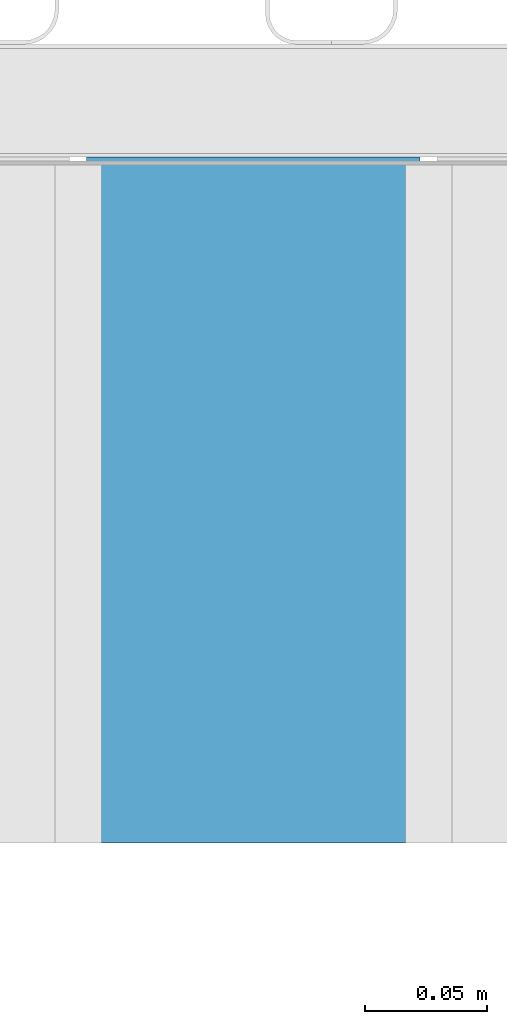
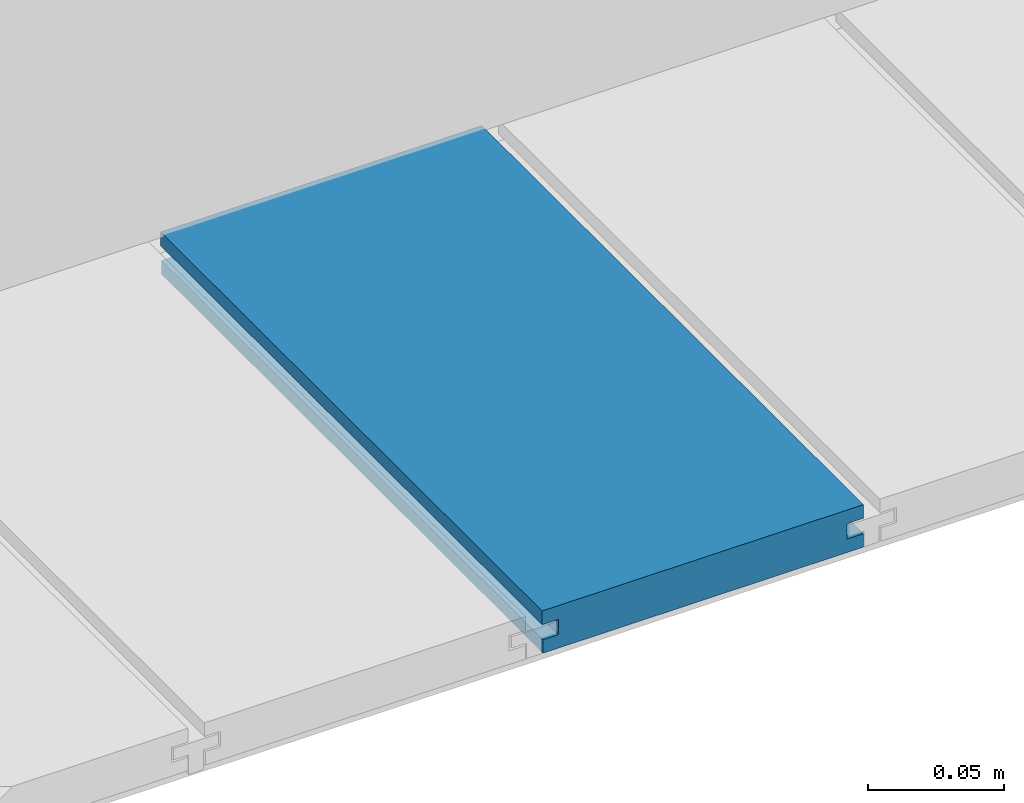
# One storey, part 14 of 33: 1 wall.
"""IFC4 building model written with IfcOpenShell, lengths in feet."""

from ifc_helpers import new_model, entity, si_unit, converted_unit, derived_unit, direction, frame, origin, place, context, subcontext, project, spatial, material, type_object, element, save


model = new_model("IFC4")

# Units and contexts
model_context = context("Model", 3, precision=0.0001, world=origin(), true_north=direction((6.12303176911189e-17, 1.0)))
body_context = subcontext(model_context, "Body", "Model", "MODEL_VIEW")
ifc_project = project(units=[converted_unit("LENGTHUNIT", "FOOT", entity("IfcRatioMeasure", 0.3048), si_unit("LENGTHUNIT", "METRE"), dimensions=[1, 0, 0, 0, 0, 0, 0]), converted_unit("AREAUNIT", "SQUARE FOOT", entity("IfcRatioMeasure", 0.09290304), si_unit("AREAUNIT", "SQUARE_METRE"), dimensions=[2, 0, 0, 0, 0, 0, 0]), converted_unit("VOLUMEUNIT", "CUBIC FOOT", entity("IfcRatioMeasure", 0.028316846592), si_unit("VOLUMEUNIT", "CUBIC_METRE"), dimensions=[3, 0, 0, 0, 0, 0, 0]), converted_unit("PLANEANGLEUNIT", "DEGREE", entity("IfcRatioMeasure", 0.0174532925199433), si_unit("PLANEANGLEUNIT", "RADIAN"), dimensions=[0, 0, 0, 0, 0, 0, 0]), si_unit("MASSUNIT", "GRAM", prefix="KILO"), derived_unit("MASSDENSITYUNIT", [(si_unit("MASSUNIT", "GRAM", prefix="KILO"), 1), (si_unit("LENGTHUNIT", "METRE"), -3)]), derived_unit("MOMENTOFINERTIAUNIT", [(si_unit("LENGTHUNIT", "METRE"), 4)]), si_unit("TIMEUNIT", "SECOND"), si_unit("FREQUENCYUNIT", "HERTZ"), si_unit("THERMODYNAMICTEMPERATUREUNIT", "DEGREE_CELSIUS"), derived_unit("THERMALTRANSMITTANCEUNIT", [(si_unit("MASSUNIT", "GRAM", prefix="KILO"), 1), (si_unit("THERMODYNAMICTEMPERATUREUNIT", "KELVIN"), -1), (si_unit("TIMEUNIT", "SECOND"), -3)]), derived_unit("VOLUMETRICFLOWRATEUNIT", [(si_unit("LENGTHUNIT", "METRE"), 3), (si_unit("TIMEUNIT", "SECOND"), -1)]), si_unit("ELECTRICCURRENTUNIT", "AMPERE"), si_unit("ELECTRICVOLTAGEUNIT", "VOLT"), si_unit("POWERUNIT", "WATT"), si_unit("FORCEUNIT", "NEWTON"), si_unit("ILLUMINANCEUNIT", "LUX"), si_unit("LUMINOUSFLUXUNIT", "LUMEN"), si_unit("LUMINOUSINTENSITYUNIT", "CANDELA"), derived_unit("USERDEFINED", [(si_unit("MASSUNIT", "GRAM", prefix="KILO"), -1), (si_unit("LENGTHUNIT", "METRE"), -2), (si_unit("TIMEUNIT", "SECOND"), 3), (si_unit("LUMINOUSFLUXUNIT", "LUMEN"), 1)]), derived_unit("LINEARVELOCITYUNIT", [(si_unit("LENGTHUNIT", "METRE"), 1), (si_unit("TIMEUNIT", "SECOND"), -1)]), si_unit("PRESSUREUNIT", "PASCAL"), derived_unit("USERDEFINED", [(si_unit("LENGTHUNIT", "METRE"), -2), (si_unit("MASSUNIT", "GRAM", prefix="KILO"), 1), (si_unit("TIMEUNIT", "SECOND"), -2)]), derived_unit("LINEARFORCEUNIT", [(si_unit("MASSUNIT", "GRAM", prefix="KILO"), 1), (si_unit("LENGTHUNIT", "METRE"), 1), (si_unit("TIMEUNIT", "SECOND"), -2), (si_unit("LENGTHUNIT", "METRE"), -1)]), derived_unit("PLANARFORCEUNIT", [(si_unit("MASSUNIT", "GRAM", prefix="KILO"), 1), (si_unit("LENGTHUNIT", "METRE"), 1), (si_unit("TIMEUNIT", "SECOND"), -2), (si_unit("LENGTHUNIT", "METRE"), -2)])], contexts=[model_context])

# Site, building, storey
site_placement = place(None, origin())
site = spatial("IfcSite", under=ifc_project, at=site_placement, CompositionType="ELEMENT")
building_placement = place(site_placement, origin())
building = spatial("IfcBuilding", under=site, at=building_placement, CompositionType="ELEMENT")
storey_placement = place(building_placement, frame((0.0, 0.0, 10.0)))
storey = spatial("IfcBuildingStorey", under=building, at=storey_placement, Name="2ND FLOOR", CompositionType="ELEMENT", Elevation=10.0000000000002)

# Wall
ifc_material = material(Name="COMPOSITE DECKING W/ HIDDEN FASTENERS", Category="Materials")
wall_type = type_object("IfcWallType", Name="Generic Models 728:Generic Models 1", PredefinedType="NOTDEFINED", material=ifc_material)
wall_placement = place(storey_placement, frame((1488.7128250319, 3.04611392999271, 0.682902157150146), z_axis=(0.0, 0.0, 1.0), x_axis=(0.0, 1.0, 0.0)))
cartesian_point_1 = entity("IfcCartesianPoint", [0.919003339851618, -0.446740923891412, 0.0])
vertex_point_1 = entity("IfcVertexPoint", cartesian_point_1)
cartesian_point_2 = entity("IfcCartesianPoint", [0.91900333985162, -0.00132475379450625, 0.0])
vertex_point_2 = entity("IfcVertexPoint", cartesian_point_2)
ifc_direction_1 = entity("IfcDirection", [0.0, 1.0, 0.0])
edge_curve_1 = entity("IfcEdgeCurve", vertex_point_1, vertex_point_2, entity("IfcTrimmedCurve", entity("IfcLine", cartesian_point_1, entity("IfcVector", ifc_direction_1, 1.0)), [cartesian_point_1], [cartesian_point_2], True, "CARTESIAN"), True)
cartesian_point_3 = entity("IfcCartesianPoint", [0.91900333985162, -0.00132475379450625, 0.0198779960861462])
vertex_point_3 = entity("IfcVertexPoint", cartesian_point_3)
ifc_direction_2 = entity("IfcDirection", [0.0, 0.0, 1.0])
edge_curve_2 = entity("IfcEdgeCurve", vertex_point_2, vertex_point_3, entity("IfcTrimmedCurve", entity("IfcLine", cartesian_point_2, entity("IfcVector", ifc_direction_2, 1.0)), [cartesian_point_2], [cartesian_point_3], True, "CARTESIAN"), True)
cartesian_point_4 = entity("IfcCartesianPoint", [0.91900333985162, -0.0228400010807945, 0.0198779960861462])
vertex_point_4 = entity("IfcVertexPoint", cartesian_point_4)
ifc_direction_3 = entity("IfcDirection", [0.0, -1.0, 0.0])
edge_curve_3 = entity("IfcEdgeCurve", vertex_point_3, vertex_point_4, entity("IfcTrimmedCurve", entity("IfcLine", cartesian_point_3, entity("IfcVector", ifc_direction_3, 1.0)), [cartesian_point_3], [cartesian_point_4], True, "CARTESIAN"), True)
cartesian_point_5 = entity("IfcCartesianPoint", [0.91900333985162, -0.0228400010807945, 0.0422987663426522])
vertex_point_5 = entity("IfcVertexPoint", cartesian_point_5)
edge_curve_4 = entity("IfcEdgeCurve", vertex_point_4, vertex_point_5, entity("IfcTrimmedCurve", entity("IfcLine", cartesian_point_4, entity("IfcVector", ifc_direction_2, 1.0)), [cartesian_point_4], [cartesian_point_5], True, "CARTESIAN"), True)
cartesian_point_6 = entity("IfcCartesianPoint", [0.91900333985162, 0.0, 0.0422987663426522])
vertex_point_6 = entity("IfcVertexPoint", cartesian_point_6)
edge_curve_5 = entity("IfcEdgeCurve", vertex_point_5, vertex_point_6, entity("IfcTrimmedCurve", entity("IfcLine", cartesian_point_5, entity("IfcVector", ifc_direction_1, 1.0)), [cartesian_point_5], [cartesian_point_6], True, "CARTESIAN"), True)
cartesian_point_7 = entity("IfcCartesianPoint", [0.91900333985162, 0.0, 0.0625000000000551])
vertex_point_7 = entity("IfcVertexPoint", cartesian_point_7)
edge_curve_6 = entity("IfcEdgeCurve", vertex_point_6, vertex_point_7, entity("IfcTrimmedCurve", entity("IfcLine", cartesian_point_6, entity("IfcVector", ifc_direction_2, 1.0)), [cartesian_point_6], [cartesian_point_7], True, "CARTESIAN"), True)
cartesian_point_8 = entity("IfcCartesianPoint", [0.919003339851618, -0.446740923891639, 0.0624999999999982])
vertex_point_8 = entity("IfcVertexPoint", cartesian_point_8)
edge_curve_7 = entity("IfcEdgeCurve", vertex_point_7, vertex_point_8, entity("IfcTrimmedCurve", entity("IfcLine", cartesian_point_7, entity("IfcVector", ifc_direction_3, 1.0)), [cartesian_point_7], [cartesian_point_8], True, "CARTESIAN"), True)
cartesian_point_9 = entity("IfcCartesianPoint", [0.919003339851618, -0.446740923891639, 0.0422987663426522])
vertex_point_9 = entity("IfcVertexPoint", cartesian_point_9)
ifc_direction_4 = entity("IfcDirection", [0.0, 0.0, -1.0])
edge_curve_8 = entity("IfcEdgeCurve", vertex_point_8, vertex_point_9, entity("IfcTrimmedCurve", entity("IfcLine", cartesian_point_8, entity("IfcVector", ifc_direction_4, 1.0)), [cartesian_point_8], [cartesian_point_9], True, "CARTESIAN"), True)
cartesian_point_10 = entity("IfcCartesianPoint", [0.919003339851618, -0.423900922810617, 0.0422987663426522])
vertex_point_10 = entity("IfcVertexPoint", cartesian_point_10)
edge_curve_9 = entity("IfcEdgeCurve", vertex_point_9, vertex_point_10, entity("IfcTrimmedCurve", entity("IfcLine", cartesian_point_9, entity("IfcVector", ifc_direction_1, 1.0)), [cartesian_point_9], [cartesian_point_10], True, "CARTESIAN"), True)
cartesian_point_11 = entity("IfcCartesianPoint", [0.919003339851618, -0.423900922810617, 0.0198779960861462])
vertex_point_11 = entity("IfcVertexPoint", cartesian_point_11)
edge_curve_10 = entity("IfcEdgeCurve", vertex_point_10, vertex_point_11, entity("IfcTrimmedCurve", entity("IfcLine", cartesian_point_10, entity("IfcVector", ifc_direction_4, 1.0)), [cartesian_point_10], [cartesian_point_11], True, "CARTESIAN"), True)
cartesian_point_12 = entity("IfcCartesianPoint", [0.919003339851618, -0.446740923891412, 0.0198779960861462])
vertex_point_12 = entity("IfcVertexPoint", cartesian_point_12)
edge_curve_11 = entity("IfcEdgeCurve", vertex_point_11, vertex_point_12, entity("IfcTrimmedCurve", entity("IfcLine", cartesian_point_11, entity("IfcVector", ifc_direction_3, 1.0)), [cartesian_point_11], [cartesian_point_12], True, "CARTESIAN"), True)
edge_curve_12 = entity("IfcEdgeCurve", vertex_point_12, vertex_point_1, entity("IfcTrimmedCurve", entity("IfcLine", cartesian_point_12, entity("IfcVector", ifc_direction_4, 1.0)), [cartesian_point_12], [cartesian_point_1], True, "CARTESIAN"), True)
ifc_direction_5 = entity("IfcDirection", [1.0, 0.0, 0.0])
cartesian_point_13 = entity("IfcCartesianPoint", [0.0, -0.446740923891412, 0.0])
vertex_point_13 = entity("IfcVertexPoint", cartesian_point_13)
cartesian_point_14 = entity("IfcCartesianPoint", [0.0, -0.446740923891412, 0.0198779960861462])
vertex_point_14 = entity("IfcVertexPoint", cartesian_point_14)
edge_curve_13 = entity("IfcEdgeCurve", vertex_point_13, vertex_point_14, entity("IfcTrimmedCurve", entity("IfcLine", cartesian_point_13, entity("IfcVector", ifc_direction_2, 1.0)), [cartesian_point_13], [cartesian_point_14], True, "CARTESIAN"), True)
cartesian_point_15 = entity("IfcCartesianPoint", [0.0, -0.423900922810617, 0.0198779960861462])
vertex_point_15 = entity("IfcVertexPoint", cartesian_point_15)
edge_curve_14 = entity("IfcEdgeCurve", vertex_point_14, vertex_point_15, entity("IfcTrimmedCurve", entity("IfcLine", cartesian_point_14, entity("IfcVector", ifc_direction_1, 1.0)), [cartesian_point_14], [cartesian_point_15], True, "CARTESIAN"), True)
cartesian_point_16 = entity("IfcCartesianPoint", [0.0, -0.423900922810617, 0.0422987663426522])
vertex_point_16 = entity("IfcVertexPoint", cartesian_point_16)
edge_curve_15 = entity("IfcEdgeCurve", vertex_point_15, vertex_point_16, entity("IfcTrimmedCurve", entity("IfcLine", cartesian_point_15, entity("IfcVector", ifc_direction_2, 1.0)), [cartesian_point_15], [cartesian_point_16], True, "CARTESIAN"), True)
cartesian_point_17 = entity("IfcCartesianPoint", [0.0, -0.446740923891639, 0.0422987663426522])
vertex_point_17 = entity("IfcVertexPoint", cartesian_point_17)
edge_curve_16 = entity("IfcEdgeCurve", vertex_point_16, vertex_point_17, entity("IfcTrimmedCurve", entity("IfcLine", cartesian_point_16, entity("IfcVector", ifc_direction_3, 1.0)), [cartesian_point_16], [cartesian_point_17], True, "CARTESIAN"), True)
cartesian_point_18 = entity("IfcCartesianPoint", [0.0, -0.446740923891639, 0.0624999999999982])
vertex_point_18 = entity("IfcVertexPoint", cartesian_point_18)
edge_curve_17 = entity("IfcEdgeCurve", vertex_point_17, vertex_point_18, entity("IfcTrimmedCurve", entity("IfcLine", cartesian_point_17, entity("IfcVector", ifc_direction_2, 1.0)), [cartesian_point_17], [cartesian_point_18], True, "CARTESIAN"), True)
cartesian_point_19 = entity("IfcCartesianPoint", [0.0, 0.0, 0.0625000000000551])
vertex_point_19 = entity("IfcVertexPoint", cartesian_point_19)
edge_curve_18 = entity("IfcEdgeCurve", vertex_point_18, vertex_point_19, entity("IfcTrimmedCurve", entity("IfcLine", cartesian_point_18, entity("IfcVector", ifc_direction_1, 1.0)), [cartesian_point_18], [cartesian_point_19], True, "CARTESIAN"), True)
cartesian_point_20 = entity("IfcCartesianPoint", [0.0, 0.0, 0.0422987663426522])
vertex_point_20 = entity("IfcVertexPoint", cartesian_point_20)
edge_curve_19 = entity("IfcEdgeCurve", vertex_point_19, vertex_point_20, entity("IfcTrimmedCurve", entity("IfcLine", cartesian_point_19, entity("IfcVector", ifc_direction_4, 1.0)), [cartesian_point_19], [cartesian_point_20], True, "CARTESIAN"), True)
cartesian_point_21 = entity("IfcCartesianPoint", [0.0, -0.0228400010807945, 0.0422987663426522])
vertex_point_21 = entity("IfcVertexPoint", cartesian_point_21)
edge_curve_20 = entity("IfcEdgeCurve", vertex_point_20, vertex_point_21, entity("IfcTrimmedCurve", entity("IfcLine", cartesian_point_20, entity("IfcVector", ifc_direction_3, 1.0)), [cartesian_point_20], [cartesian_point_21], True, "CARTESIAN"), True)
cartesian_point_22 = entity("IfcCartesianPoint", [0.0, -0.0228400010807945, 0.0198779960861462])
vertex_point_22 = entity("IfcVertexPoint", cartesian_point_22)
edge_curve_21 = entity("IfcEdgeCurve", vertex_point_21, vertex_point_22, entity("IfcTrimmedCurve", entity("IfcLine", cartesian_point_21, entity("IfcVector", ifc_direction_4, 1.0)), [cartesian_point_21], [cartesian_point_22], True, "CARTESIAN"), True)
cartesian_point_23 = entity("IfcCartesianPoint", [0.0, -0.00132475379450625, 0.0198779960861462])
vertex_point_23 = entity("IfcVertexPoint", cartesian_point_23)
edge_curve_22 = entity("IfcEdgeCurve", vertex_point_22, vertex_point_23, entity("IfcTrimmedCurve", entity("IfcLine", cartesian_point_22, entity("IfcVector", ifc_direction_1, 1.0)), [cartesian_point_22], [cartesian_point_23], True, "CARTESIAN"), True)
cartesian_point_24 = entity("IfcCartesianPoint", [0.0, -0.00132475379450625, 0.0])
vertex_point_24 = entity("IfcVertexPoint", cartesian_point_24)
edge_curve_23 = entity("IfcEdgeCurve", vertex_point_23, vertex_point_24, entity("IfcTrimmedCurve", entity("IfcLine", cartesian_point_23, entity("IfcVector", ifc_direction_4, 1.0)), [cartesian_point_23], [cartesian_point_24], True, "CARTESIAN"), True)
edge_curve_24 = entity("IfcEdgeCurve", vertex_point_24, vertex_point_13, entity("IfcTrimmedCurve", entity("IfcLine", cartesian_point_24, entity("IfcVector", ifc_direction_3, 1.0)), [cartesian_point_24], [cartesian_point_13], True, "CARTESIAN"), True)
ifc_direction_6 = entity("IfcDirection", [-1.0, 0.0, 0.0])
edge_curve_25 = entity("IfcEdgeCurve", vertex_point_13, vertex_point_1, entity("IfcTrimmedCurve", entity("IfcLine", cartesian_point_13, entity("IfcVector", ifc_direction_5, 1.0)), [cartesian_point_13], [cartesian_point_1], True, "CARTESIAN"), True)
edge_curve_26 = entity("IfcEdgeCurve", vertex_point_12, vertex_point_14, entity("IfcTrimmedCurve", entity("IfcLine", cartesian_point_14, entity("IfcVector", ifc_direction_6, 1.0)), [cartesian_point_12], [cartesian_point_14], True, "CARTESIAN"), True)
edge_curve_27 = entity("IfcEdgeCurve", vertex_point_18, vertex_point_8, entity("IfcTrimmedCurve", entity("IfcLine", cartesian_point_18, entity("IfcVector", ifc_direction_5, 1.0)), [cartesian_point_18], [cartesian_point_8], True, "CARTESIAN"), True)
edge_curve_28 = entity("IfcEdgeCurve", vertex_point_7, vertex_point_19, entity("IfcTrimmedCurve", entity("IfcLine", cartesian_point_19, entity("IfcVector", ifc_direction_6, 1.0)), [cartesian_point_7], [cartesian_point_19], True, "CARTESIAN"), True)
edge_curve_29 = entity("IfcEdgeCurve", vertex_point_6, vertex_point_20, entity("IfcTrimmedCurve", entity("IfcLine", cartesian_point_20, entity("IfcVector", ifc_direction_6, 1.0)), [cartesian_point_6], [cartesian_point_20], True, "CARTESIAN"), True)
edge_curve_30 = entity("IfcEdgeCurve", vertex_point_24, vertex_point_2, entity("IfcTrimmedCurve", entity("IfcLine", cartesian_point_24, entity("IfcVector", ifc_direction_5, 1.0)), [cartesian_point_24], [cartesian_point_2], True, "CARTESIAN"), True)
edge_curve_31 = entity("IfcEdgeCurve", vertex_point_17, vertex_point_9, entity("IfcTrimmedCurve", entity("IfcLine", cartesian_point_17, entity("IfcVector", ifc_direction_5, 1.0)), [cartesian_point_17], [cartesian_point_9], True, "CARTESIAN"), True)
edge_curve_32 = entity("IfcEdgeCurve", vertex_point_5, vertex_point_21, entity("IfcTrimmedCurve", entity("IfcLine", cartesian_point_21, entity("IfcVector", ifc_direction_6, 1.0)), [cartesian_point_5], [cartesian_point_21], True, "CARTESIAN"), True)
edge_curve_33 = entity("IfcEdgeCurve", vertex_point_4, vertex_point_22, entity("IfcTrimmedCurve", entity("IfcLine", cartesian_point_22, entity("IfcVector", ifc_direction_6, 1.0)), [cartesian_point_4], [cartesian_point_22], True, "CARTESIAN"), True)
edge_curve_34 = entity("IfcEdgeCurve", vertex_point_3, vertex_point_23, entity("IfcTrimmedCurve", entity("IfcLine", cartesian_point_23, entity("IfcVector", ifc_direction_6, 1.0)), [cartesian_point_3], [cartesian_point_23], True, "CARTESIAN"), True)
edge_curve_35 = entity("IfcEdgeCurve", vertex_point_11, vertex_point_15, entity("IfcTrimmedCurve", entity("IfcLine", cartesian_point_15, entity("IfcVector", ifc_direction_6, 1.0)), [cartesian_point_11], [cartesian_point_15], True, "CARTESIAN"), True)
edge_curve_36 = entity("IfcEdgeCurve", vertex_point_10, vertex_point_16, entity("IfcTrimmedCurve", entity("IfcLine", cartesian_point_16, entity("IfcVector", ifc_direction_6, 1.0)), [cartesian_point_10], [cartesian_point_16], True, "CARTESIAN"), True)
element("IfcWall", 1, at=wall_placement, inside=storey, type_object=wall_type, material=ifc_material, Name="Generic Models 728:Generic Models 1", ObjectType="Generic Models 728:Generic Models 1", PredefinedType="NOTDEFINED", context=body_context, shape_type="AdvancedBrep", body=[
    entity("IfcAdvancedBrep", entity("IfcClosedShell", [entity("IfcAdvancedFace", [entity("IfcFaceOuterBound", entity("IfcEdgeLoop", [entity("IfcOrientedEdge", None, None, edge_curve_1, True), entity("IfcOrientedEdge", None, None, edge_curve_2, True), entity("IfcOrientedEdge", None, None, edge_curve_3, True), entity("IfcOrientedEdge", None, None, edge_curve_4, True), entity("IfcOrientedEdge", None, None, edge_curve_5, True), entity("IfcOrientedEdge", None, None, edge_curve_6, True), entity("IfcOrientedEdge", None, None, edge_curve_7, True), entity("IfcOrientedEdge", None, None, edge_curve_8, True), entity("IfcOrientedEdge", None, None, edge_curve_9, True), entity("IfcOrientedEdge", None, None, edge_curve_10, True), entity("IfcOrientedEdge", None, None, edge_curve_11, True), entity("IfcOrientedEdge", None, None, edge_curve_12, True)]), True)], entity("IfcPlane", entity("IfcAxis2Placement3D", entity("IfcCartesianPoint", [0.919003339851618, -0.446740923891412, -0.0208333333328241]), ifc_direction_5, ifc_direction_4)), True), entity("IfcAdvancedFace", [entity("IfcFaceOuterBound", entity("IfcEdgeLoop", [entity("IfcOrientedEdge", None, None, edge_curve_13, True), entity("IfcOrientedEdge", None, None, edge_curve_14, True), entity("IfcOrientedEdge", None, None, edge_curve_15, True), entity("IfcOrientedEdge", None, None, edge_curve_16, True), entity("IfcOrientedEdge", None, None, edge_curve_17, True), entity("IfcOrientedEdge", None, None, edge_curve_18, True), entity("IfcOrientedEdge", None, None, edge_curve_19, True), entity("IfcOrientedEdge", None, None, edge_curve_20, True), entity("IfcOrientedEdge", None, None, edge_curve_21, True), entity("IfcOrientedEdge", None, None, edge_curve_22, True), entity("IfcOrientedEdge", None, None, edge_curve_23, True), entity("IfcOrientedEdge", None, None, edge_curve_24, True)]), True)], entity("IfcPlane", entity("IfcAxis2Placement3D", entity("IfcCartesianPoint", [0.0, -0.446740923891412, -0.0208333333328241]), ifc_direction_6, ifc_direction_2)), True), entity("IfcAdvancedFace", [entity("IfcFaceOuterBound", entity("IfcEdgeLoop", [entity("IfcOrientedEdge", None, None, edge_curve_13, False), entity("IfcOrientedEdge", None, None, edge_curve_25, True), entity("IfcOrientedEdge", None, None, edge_curve_12, False), entity("IfcOrientedEdge", None, None, edge_curve_26, True)]), True)], entity("IfcPlane", entity("IfcAxis2Placement3D", cartesian_point_13, ifc_direction_3, ifc_direction_5)), True), entity("IfcAdvancedFace", [entity("IfcFaceOuterBound", entity("IfcEdgeLoop", [entity("IfcOrientedEdge", None, None, edge_curve_18, False), entity("IfcOrientedEdge", None, None, edge_curve_27, True), entity("IfcOrientedEdge", None, None, edge_curve_7, False), entity("IfcOrientedEdge", None, None, edge_curve_28, True)]), True)], entity("IfcPlane", entity("IfcAxis2Placement3D", cartesian_point_18, ifc_direction_2, ifc_direction_5)), True), entity("IfcAdvancedFace", [entity("IfcFaceOuterBound", entity("IfcEdgeLoop", [entity("IfcOrientedEdge", None, None, edge_curve_19, False), entity("IfcOrientedEdge", None, None, edge_curve_28, False), entity("IfcOrientedEdge", None, None, edge_curve_6, False), entity("IfcOrientedEdge", None, None, edge_curve_29, True)]), True)], entity("IfcPlane", entity("IfcAxis2Placement3D", cartesian_point_19, ifc_direction_1, ifc_direction_5)), True), entity("IfcAdvancedFace", [entity("IfcFaceOuterBound", entity("IfcEdgeLoop", [entity("IfcOrientedEdge", None, None, edge_curve_24, False), entity("IfcOrientedEdge", None, None, edge_curve_30, True), entity("IfcOrientedEdge", None, None, edge_curve_1, False), entity("IfcOrientedEdge", None, None, edge_curve_25, False)]), True)], entity("IfcPlane", entity("IfcAxis2Placement3D", cartesian_point_24, ifc_direction_4, ifc_direction_5)), True), entity("IfcAdvancedFace", [entity("IfcFaceOuterBound", entity("IfcEdgeLoop", [entity("IfcOrientedEdge", None, None, edge_curve_17, False), entity("IfcOrientedEdge", None, None, edge_curve_31, True), entity("IfcOrientedEdge", None, None, edge_curve_8, False), entity("IfcOrientedEdge", None, None, edge_curve_27, False)]), True)], entity("IfcPlane", entity("IfcAxis2Placement3D", cartesian_point_17, ifc_direction_3, ifc_direction_5)), True), entity("IfcAdvancedFace", [entity("IfcFaceOuterBound", entity("IfcEdgeLoop", [entity("IfcOrientedEdge", None, None, edge_curve_20, False), entity("IfcOrientedEdge", None, None, edge_curve_29, False), entity("IfcOrientedEdge", None, None, edge_curve_5, False), entity("IfcOrientedEdge", None, None, edge_curve_32, True)]), True)], entity("IfcPlane", entity("IfcAxis2Placement3D", cartesian_point_20, ifc_direction_4, ifc_direction_5)), True), entity("IfcAdvancedFace", [entity("IfcFaceOuterBound", entity("IfcEdgeLoop", [entity("IfcOrientedEdge", None, None, edge_curve_21, False), entity("IfcOrientedEdge", None, None, edge_curve_32, False), entity("IfcOrientedEdge", None, None, edge_curve_4, False), entity("IfcOrientedEdge", None, None, edge_curve_33, True)]), True)], entity("IfcPlane", entity("IfcAxis2Placement3D", cartesian_point_21, ifc_direction_1, ifc_direction_5)), True), entity("IfcAdvancedFace", [entity("IfcFaceOuterBound", entity("IfcEdgeLoop", [entity("IfcOrientedEdge", None, None, edge_curve_22, False), entity("IfcOrientedEdge", None, None, edge_curve_33, False), entity("IfcOrientedEdge", None, None, edge_curve_3, False), entity("IfcOrientedEdge", None, None, edge_curve_34, True)]), True)], entity("IfcPlane", entity("IfcAxis2Placement3D", cartesian_point_22, ifc_direction_2, ifc_direction_5)), True), entity("IfcAdvancedFace", [entity("IfcFaceOuterBound", entity("IfcEdgeLoop", [entity("IfcOrientedEdge", None, None, edge_curve_23, False), entity("IfcOrientedEdge", None, None, edge_curve_34, False), entity("IfcOrientedEdge", None, None, edge_curve_2, False), entity("IfcOrientedEdge", None, None, edge_curve_30, False)]), True)], entity("IfcPlane", entity("IfcAxis2Placement3D", cartesian_point_23, ifc_direction_1, ifc_direction_5)), True), entity("IfcAdvancedFace", [entity("IfcFaceOuterBound", entity("IfcEdgeLoop", [entity("IfcOrientedEdge", None, None, edge_curve_14, False), entity("IfcOrientedEdge", None, None, edge_curve_26, False), entity("IfcOrientedEdge", None, None, edge_curve_11, False), entity("IfcOrientedEdge", None, None, edge_curve_35, True)]), True)], entity("IfcPlane", entity("IfcAxis2Placement3D", cartesian_point_14, ifc_direction_2, ifc_direction_5)), True), entity("IfcAdvancedFace", [entity("IfcFaceOuterBound", entity("IfcEdgeLoop", [entity("IfcOrientedEdge", None, None, edge_curve_15, False), entity("IfcOrientedEdge", None, None, edge_curve_35, False), entity("IfcOrientedEdge", None, None, edge_curve_10, False), entity("IfcOrientedEdge", None, None, edge_curve_36, True)]), True)], entity("IfcPlane", entity("IfcAxis2Placement3D", cartesian_point_15, ifc_direction_3, ifc_direction_5)), True), entity("IfcAdvancedFace", [entity("IfcFaceOuterBound", entity("IfcEdgeLoop", [entity("IfcOrientedEdge", None, None, edge_curve_16, False), entity("IfcOrientedEdge", None, None, edge_curve_36, False), entity("IfcOrientedEdge", None, None, edge_curve_9, False), entity("IfcOrientedEdge", None, None, edge_curve_31, False)]), True)], entity("IfcPlane", entity("IfcAxis2Placement3D", cartesian_point_16, ifc_direction_4, ifc_direction_5)), True)])),
])

save(model, "model.ifc")
